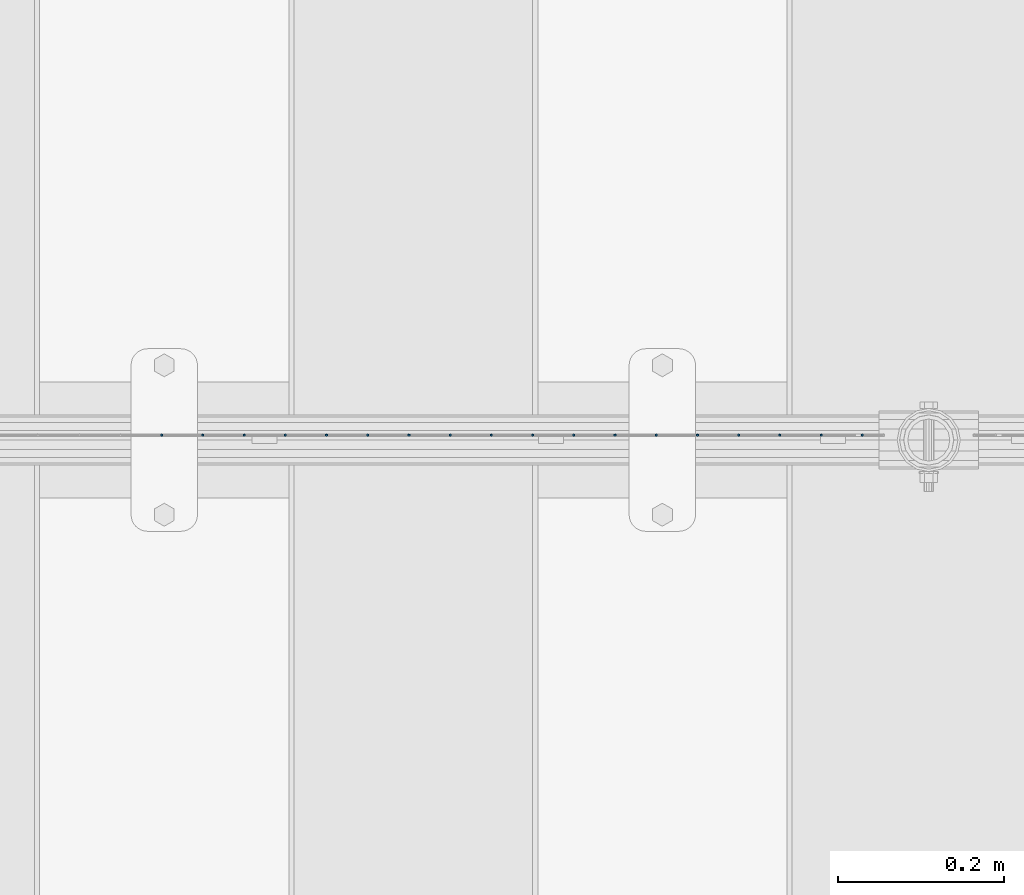
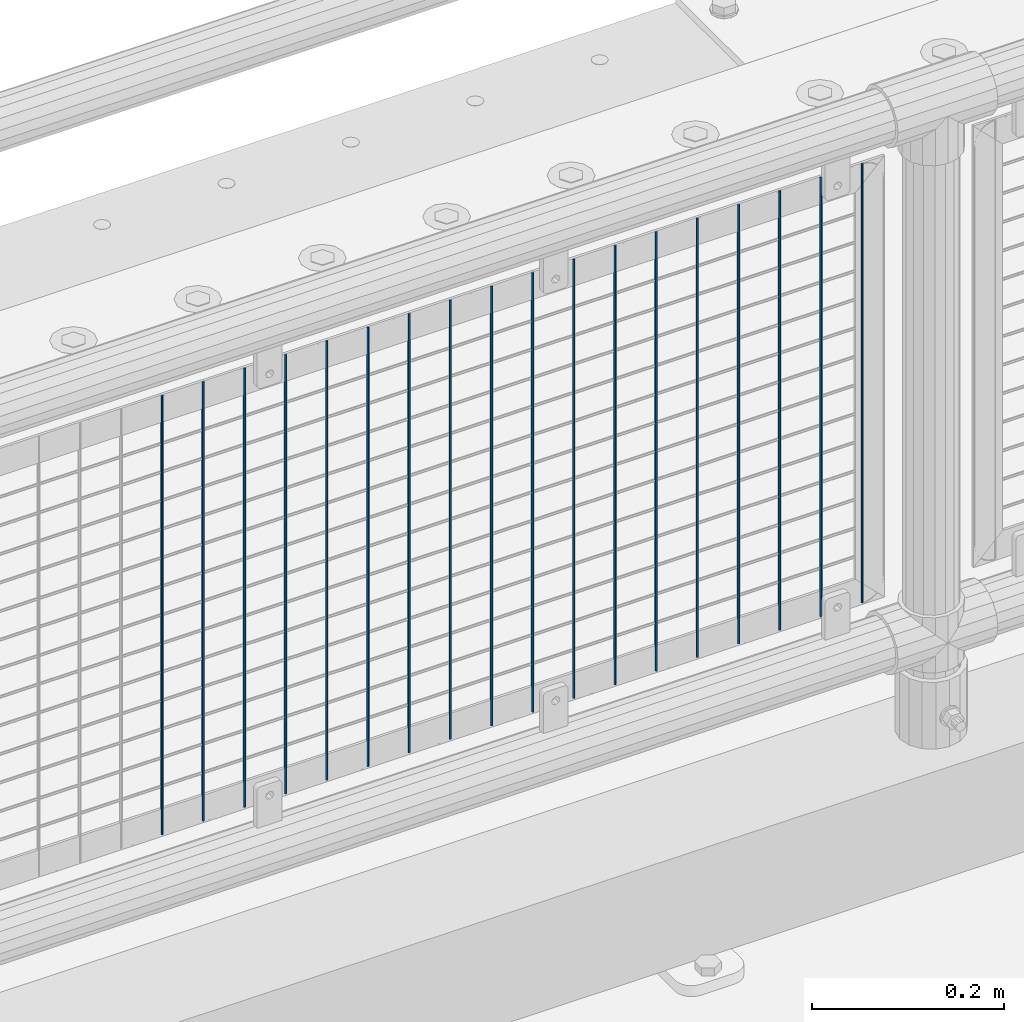
# One storey, part 65 of 208: 18 columns.
"""IFC2X3 building model written with IfcOpenShell, lengths in millimetres."""

from ifc_helpers import new_model, si_unit, frame, origin_with_axes, place, context, subcontext, project, spatial, faceted_brep, material, type_object, element, save


model = new_model("IFC2X3")

# Units and contexts
model_context = context("Model", 3, precision=1e-05, world=origin_with_axes())
body_context = subcontext(model_context, "Body", "Model", "MODEL_VIEW")
ifc_project = project(units=[si_unit("LENGTHUNIT", "METRE", prefix="MILLI"), si_unit("AREAUNIT", "SQUARE_METRE"), si_unit("VOLUMEUNIT", "CUBIC_METRE"), si_unit("MASSUNIT", "GRAM", prefix="KILO"), si_unit("TIMEUNIT", "SECOND"), si_unit("PLANEANGLEUNIT", "RADIAN"), si_unit("SOLIDANGLEUNIT", "STERADIAN"), si_unit("THERMODYNAMICTEMPERATUREUNIT", "DEGREE_CELSIUS"), si_unit("LUMINOUSINTENSITYUNIT", "LUMEN")], contexts=[model_context])

# Site, building, storey
site_placement = place(None, origin_with_axes())
site = spatial("IfcSite", under=ifc_project, at=site_placement, CompositionType="ELEMENT")
building_placement = place(site_placement, origin_with_axes())
building = spatial("IfcBuilding", under=site, at=building_placement, Name="Standard", CompositionType="ELEMENT")
storey_placement = place(building_placement, origin_with_axes())
storey = spatial("IfcBuildingStorey", under=building, at=storey_placement, Name="Undefined", CompositionType="ELEMENT", Elevation=0.0)

# Columns
ifc_material = material(Name="Misc_Undefined")
column_type = type_object("IfcColumnType", Name="D3", PredefinedType="NOTDEFINED")
for number, where, z_axis, x_axis in (
    (1, (-35509.005, 4670.50000000001, 353.020000000001), (-1.0, 0.0, 0.0), (0.0, 0.0, 1.0)),
    (2, (-35558.66, 4670.50000000001, 353.020000000001), (-1.0, 0.0, 0.0), (0.0, 0.0, 1.0)),
    (3, (-35608.315, 4670.50000000001, 353.020000000001), (-1.0, 0.0, 0.0), (0.0, 0.0, 1.0)),
    (4, (-35657.97, 4670.50000000001, 353.020000000001), (-1.0, 0.0, 0.0), (0.0, 0.0, 1.0)),
    (5, (-35707.625, 4670.5, 353.020000000001), (-1.0, 0.0, 0.0), (0.0, 0.0, 1.0)),
    (6, (-35757.28, 4670.5, 353.020000000001), (-1.0, 0.0, 0.0), (0.0, 0.0, 1.0)),
    (7, (-35806.935, 4670.5, 353.020000000001), (-1.0, 0.0, 0.0), (0.0, 0.0, 1.0)),
    (8, (-35856.59, 4670.5, 353.020000000001), (-1.0, 0.0, 0.0), (0.0, 0.0, 1.0)),
    (9, (-35906.245, 4670.5, 353.020000000001), (-1.0, 0.0, 0.0), (0.0, 0.0, 1.0)),
    (10, (-35955.9, 4670.5, 353.020000000001), (-1.0, 0.0, 0.0), (0.0, 0.0, 1.0)),
    (11, (-36005.555, 4670.5, 353.020000000001), (-1.0, 0.0, 0.0), (0.0, 0.0, 1.0)),
    (12, (-36055.21, 4670.5, 353.020000000001), (-1.0, 0.0, 0.0), (0.0, 0.0, 1.0)),
    (13, (-36104.865, 4670.5, 353.020000000001), (-1.0, 0.0, 0.0), (0.0, 0.0, 1.0)),
    (14, (-36154.52, 4670.5, 353.020000000001), (-1.0, 0.0, 0.0), (0.0, 0.0, 1.0)),
    (15, (-36204.175, 4670.5, 353.020000000001), (-1.0, 0.0, 0.0), (0.0, 0.0, 1.0)),
    (16, (-36253.83, 4670.5, 353.020000000001), (-1.0, 0.0, 0.0), (0.0, 0.0, 1.0)),
    (17, (-36303.485, 4670.5, 353.020000000001), (-1.0, 0.0, 0.0), (0.0, 0.0, 1.0)),
    (18, (-36353.14, 4670.5, 353.020000000001), (-1.0, 0.0, 0.0), (0.0, 0.0, 1.0)),
):
    element("IfcColumn", number, at=place(storey_placement, frame(where, z_axis=z_axis, x_axis=x_axis)), inside=storey, type_object=column_type, material=ifc_material, ObjectType="D3", context=body_context, shape_type="Brep", body=[
        faceted_brep([(0.0, -1.49999999999909, 3.63797880709171e-12), (-7.27595761418343e-12, -0.749999999999091, -1.29903810567669), (560.0, -0.75, -1.29903810567703), (560.0, -1.5, 0.0), (-3.63797880709171e-12, 0.750000000000909, -1.29903810567669), (560.0, 0.75, -1.29903810567703), (0.0, 1.50000000000182, 3.63797880709171e-12), (560.0, 1.5, 0.0), (-3.63797880709171e-12, 0.750000000000909, 1.29903810567669), (560.0, 0.75, 1.29903810567703), (-7.27595761418343e-12, -0.749999999999091, 1.29903810567669), (560.0, -0.75, 1.29903810567703)], [[[0, 1, 2, 3]], [[1, 4, 5, 2]], [[4, 6, 7, 5]], [[6, 8, 9, 7]], [[8, 10, 11, 9]], [[10, 0, 3, 11]], [[5, 7, 9, 11, 3, 2]], [[10, 8, 6, 4, 1, 0]]]),
    ])

save(model, "model.ifc")
